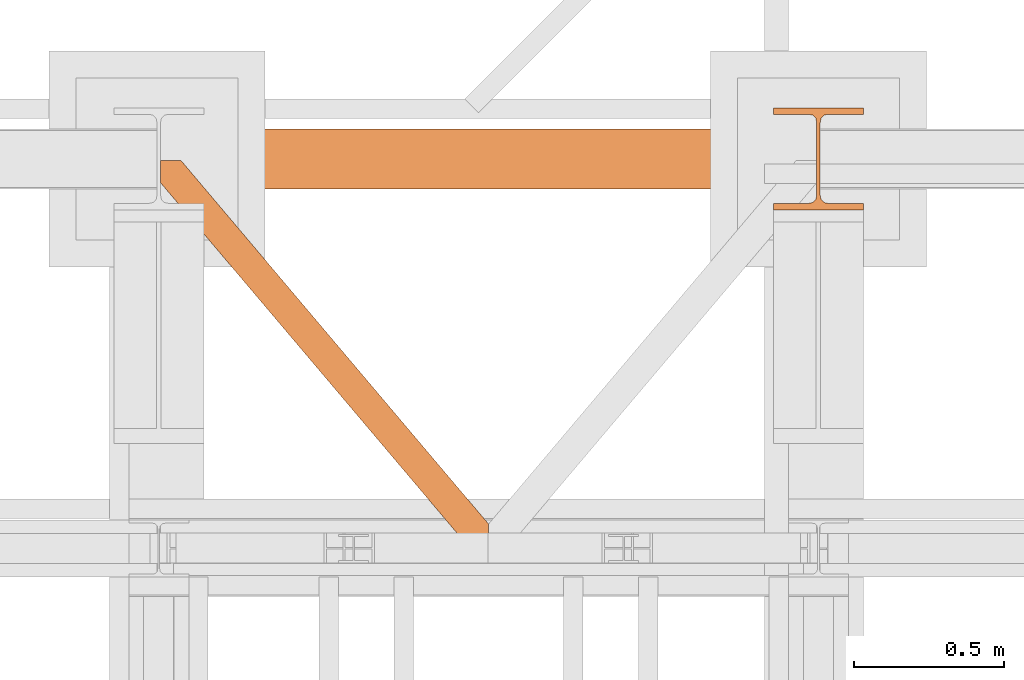
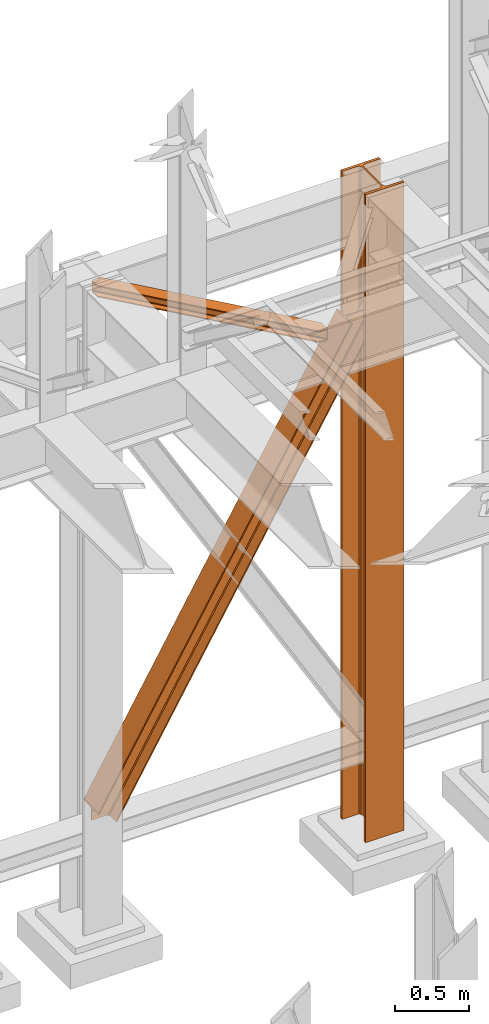
# One storey, part 192 of 208: 3 proxies.
"""IFC2X3 building model written with IfcOpenShell, lengths in millimetres."""

from ifc_helpers import new_model, entity, si_unit, converted_unit, frame, origin, origin_with_axes, place, context, subcontext, project, spatial, faceted_brep, material, element, save


model = new_model("IFC2X3")

# Units and contexts
model_context = context("Model", 3, precision=1e-05, world=origin())
plan_context = context("Plan", 3, precision=1e-05, world=origin())
body_context = subcontext(model_context, "Body", "Model", "MODEL_VIEW")
ifc_project = project(units=[si_unit("LENGTHUNIT", "METRE", prefix="MILLI"), converted_unit("PLANEANGLEUNIT", "DEGREE", entity("IfcPlaneAngleMeasure", 0.0174532925199433), si_unit("PLANEANGLEUNIT", "RADIAN"), dimensions=[0, 0, 0, 0, 0, 0, 0]), si_unit("AREAUNIT", "SQUARE_METRE"), si_unit("VOLUMEUNIT", "CUBIC_METRE")], contexts=[model_context, plan_context])

# Building, storey
building_placement = place(None, origin())
building = spatial("IfcBuilding", under=ifc_project, at=building_placement, CompositionType="COMPLEX")
storey_placement = place(building_placement, origin_with_axes())
storey = spatial("IfcBuildingStorey", under=building, at=storey_placement, Name="Geschoss", CompositionType="ELEMENT")

# Proxies
ifc_material = material(Name="35/80cm")
proxy_1_placement = place(storey_placement, frame((5343.254962568202, -12632.57439531566, -65.01000000000022), z_axis=(0.0, 0.0, 1.0), x_axis=(1.0, 0.0, 0.0)))
element("IfcBuildingElementProxy", 1, at=proxy_1_placement, inside=storey, material=ifc_material, context=body_context, shape_type="Brep", body=[
    faceted_brep([(300.0100119209292, 0.01000000000021828, 0.01000000000027512), (300.0100119209292, 21.51000631809256, 0.01000000000027512), (183.0100057816508, 21.51000631809256, 0.01000000000027512), (169.036290997863, 24.30682016372703, 0.01000000000027512), (158.8068282401564, 34.53628850936912, 0.01000000000027512), (156.0100060126188, 48.51000143051169, 0.01000000000027512), (156.0100060126188, 291.5099946951868, 0.01000000000027512), (158.8068282401564, 305.48371506691, 0.01000000000027512), (169.036290997863, 315.7131685113909, 0.01000000000027512), (183.0100057816508, 318.5099972581866, 0.01000000000027512), (300.0100119209292, 318.5099972581866, 0.01000000000027512), (300.0100119209292, 340.0100035762789, 0.01000000000027512), (0.01000000000021828, 340.0100035762789, 0.01000000000027512), (0.01000000000021828, 318.5099972581866, 0.01000000000027512), (117.0100061392786, 318.5099972581866, 0.01000000000027512), (130.9837209230664, 315.7131685113909, 0.01000000000027512), (141.213183680773, 305.48371506691, 0.01000000000027512), (144.0100059083106, 291.5099946951868, 0.01000000000027512), (144.0100059083106, 48.51000143051169, 0.01000000000027512), (141.213183680773, 34.53628850936912, 0.01000000000027512), (130.9837209230664, 24.30682016372703, 0.01000000000027512), (117.0100061392786, 21.51000631809256, 0.01000000000027512), (0.01000000000021828, 21.51000631809256, 0.01000000000027512), (0.01000000000021828, 0.01000000000021828, 0.01000000000027512), (300.0100119209292, 21.51000631809256, 5350.010005364416), (300.0100119209292, 0.01000000000021828, 5350.010005364416), (0.01000000000021828, 0.01000000000021828, 5350.010005364416), (0.01000000000021828, 21.51000631809256, 5350.010005364416), (117.0100061392786, 21.51000631809256, 5350.010005364416), (130.9837209230664, 24.30682016372703, 5350.010005364416), (141.213183680773, 34.53628850936912, 5350.010005364416), (144.0100059083106, 48.51000143051169, 5350.010005364416), (144.0100059083106, 291.5099946951868, 5350.010005364416), (141.213183680773, 305.48371506691, 5350.010005364416), (130.9837209230664, 315.7131685113909, 5350.010005364416), (117.0100061392786, 318.5099972581866, 5350.010005364416), (0.01000000000021828, 318.5099972581866, 5350.010005364416), (0.01000000000021828, 340.0100035762789, 5350.010005364416), (300.0100119209292, 340.0100035762789, 5350.010005364416), (300.0100119209292, 318.5099972581866, 5350.010005364416), (183.0100057816508, 318.5099972581866, 5350.010005364416), (169.036290997863, 315.7131685113909, 5350.010005364416), (158.8068282401564, 305.48371506691, 5350.010005364416), (156.0100060126188, 291.5099946951868, 5350.010005364416), (156.0100060126188, 48.51000143051169, 5350.010005364416), (158.8068282401564, 34.53628850936912, 5350.010005364416), (169.036290997863, 24.30682016372703, 5350.010005364416), (183.0100057816508, 21.51000631809256, 5350.010005364416), (300.0100119209292, 21.51000631809256, 0.01000000000027512), (300.0100119209292, 0.01000000000021828, 0.01000000000027512), (300.0100119209292, 0.01000000000021828, 5350.010005364416), (300.0100119209292, 21.51000631809256, 5350.010005364416), (183.0100057816508, 21.51000631809256, 0.01000000000027512), (300.0100119209292, 21.51000631809256, 0.01000000000027512), (300.0100119209292, 21.51000631809256, 5350.010005364416), (183.0100057816508, 21.51000631809256, 5350.010005364416), (169.036290997863, 24.30682016372703, 0.01000000000027512), (183.0100057816508, 21.51000631809256, 0.01000000000027512), (183.0100057816508, 21.51000631809256, 5350.010005364416), (169.036290997863, 24.30682016372703, 5350.010005364416), (158.8068282401564, 34.53628850936912, 0.01000000000027512), (169.036290997863, 24.30682016372703, 0.01000000000027512), (169.036290997863, 24.30682016372703, 5350.010005364416), (158.8068282401564, 34.53628850936912, 5350.010005364416), (156.0100060126188, 48.51000143051169, 0.01000000000027512), (158.8068282401564, 34.53628850936912, 0.01000000000027512), (158.8068282401564, 34.53628850936912, 5350.010005364416), (156.0100060126188, 48.51000143051169, 5350.010005364416), (156.0100060126188, 291.5099946951868, 0.01000000000027512), (156.0100060126188, 48.51000143051169, 0.01000000000027512), (156.0100060126188, 48.51000143051169, 5350.010005364416), (156.0100060126188, 291.5099946951868, 5350.010005364416), (158.8068282401564, 305.48371506691, 0.01000000000027512), (156.0100060126188, 291.5099946951868, 0.01000000000027512), (156.0100060126188, 291.5099946951868, 5350.010005364416), (158.8068282401564, 305.48371506691, 5350.010005364416), (169.036290997863, 315.7131685113909, 0.01000000000027512), (158.8068282401564, 305.48371506691, 0.01000000000027512), (158.8068282401564, 305.48371506691, 5350.010005364416), (169.036290997863, 315.7131685113909, 5350.010005364416), (183.0100057816508, 318.5099972581866, 0.01000000000027512), (169.036290997863, 315.7131685113909, 0.01000000000027512), (169.036290997863, 315.7131685113909, 5350.010005364416), (183.0100057816508, 318.5099972581866, 5350.010005364416), (300.0100119209292, 318.5099972581866, 0.01000000000027512), (183.0100057816508, 318.5099972581866, 0.01000000000027512), (183.0100057816508, 318.5099972581866, 5350.010005364416), (300.0100119209292, 318.5099972581866, 5350.010005364416), (300.0100119209292, 340.0100035762789, 0.01000000000027512), (300.0100119209292, 318.5099972581866, 0.01000000000027512), (300.0100119209292, 318.5099972581866, 5350.010005364416), (300.0100119209292, 340.0100035762789, 5350.010005364416), (0.01000000000021828, 340.0100035762789, 0.01000000000027512), (300.0100119209292, 340.0100035762789, 0.01000000000027512), (300.0100119209292, 340.0100035762789, 5350.010005364416), (0.01000000000021828, 340.0100035762789, 5350.010005364416), (0.01000000000021828, 318.5099972581866, 0.01000000000027512), (0.01000000000021828, 340.0100035762789, 0.01000000000027512), (0.01000000000021828, 340.0100035762789, 5350.010005364416), (0.01000000000021828, 318.5099972581866, 5350.010005364416), (117.0100061392786, 318.5099972581866, 0.01000000000027512), (0.01000000000021828, 318.5099972581866, 0.01000000000027512), (0.01000000000021828, 318.5099972581866, 5350.010005364416), (117.0100061392786, 318.5099972581866, 5350.010005364416), (130.9837209230664, 315.7131685113909, 0.01000000000027512), (117.0100061392786, 318.5099972581866, 0.01000000000027512), (117.0100061392786, 318.5099972581866, 5350.010005364416), (130.9837209230664, 315.7131685113909, 5350.010005364416), (141.213183680773, 305.48371506691, 0.01000000000027512), (130.9837209230664, 315.7131685113909, 0.01000000000027512), (130.9837209230664, 315.7131685113909, 5350.010005364416), (141.213183680773, 305.48371506691, 5350.010005364416), (144.0100059083106, 291.5099946951868, 0.01000000000027512), (141.213183680773, 305.48371506691, 0.01000000000027512), (141.213183680773, 305.48371506691, 5350.010005364416), (144.0100059083106, 291.5099946951868, 5350.010005364416), (144.0100059083106, 48.51000143051169, 0.01000000000027512), (144.0100059083106, 291.5099946951868, 0.01000000000027512), (144.0100059083106, 291.5099946951868, 5350.010005364416), (144.0100059083106, 48.51000143051169, 5350.010005364416), (141.213183680773, 34.53628850936912, 0.01000000000027512), (144.0100059083106, 48.51000143051169, 0.01000000000027512), (144.0100059083106, 48.51000143051169, 5350.010005364416), (141.213183680773, 34.53628850936912, 5350.010005364416), (130.9837209230664, 24.30682016372703, 0.01000000000027512), (141.213183680773, 34.53628850936912, 0.01000000000027512), (141.213183680773, 34.53628850936912, 5350.010005364416), (130.9837209230664, 24.30682016372703, 5350.010005364416), (117.0100061392786, 21.51000631809256, 0.01000000000027512), (130.9837209230664, 24.30682016372703, 0.01000000000027512), (130.9837209230664, 24.30682016372703, 5350.010005364416), (117.0100061392786, 21.51000631809256, 5350.010005364416), (0.01000000000021828, 21.51000631809256, 0.01000000000027512), (117.0100061392786, 21.51000631809256, 0.01000000000027512), (117.0100061392786, 21.51000631809256, 5350.010005364416), (0.01000000000021828, 21.51000631809256, 5350.010005364416), (0.01000000000021828, 0.01000000000021828, 0.01000000000027512), (0.01000000000021828, 21.51000631809256, 0.01000000000027512), (0.01000000000021828, 21.51000631809256, 5350.010005364416), (0.01000000000021828, 0.01000000000021828, 5350.010005364416), (300.0100119209292, 0.01000000000021828, 0.01000000000027512), (0.01000000000021828, 0.01000000000021828, 0.01000000000027512), (0.01000000000021828, 0.01000000000021828, 5350.010005364416), (300.0100119209292, 0.01000000000021828, 5350.010005364416)], [[[0, 1, 2, 3, 4, 5, 6, 7, 8, 9, 10, 11, 12, 13, 14, 15, 16, 17, 18, 19, 20, 21, 22, 23]], [[24, 25, 26, 27, 28, 29, 30, 31, 32, 33, 34, 35, 36, 37, 38, 39, 40, 41, 42, 43, 44, 45, 46, 47]], [[48, 49, 50, 51]], [[52, 53, 54, 55]], [[56, 57, 58, 59]], [[60, 61, 62, 63]], [[64, 65, 66, 67]], [[68, 69, 70, 71]], [[72, 73, 74, 75]], [[76, 77, 78, 79]], [[80, 81, 82, 83]], [[84, 85, 86, 87]], [[88, 89, 90, 91]], [[92, 93, 94, 95]], [[96, 97, 98, 99]], [[100, 101, 102, 103]], [[104, 105, 106, 107]], [[108, 109, 110, 111]], [[112, 113, 114, 115]], [[116, 117, 118, 119]], [[120, 121, 122, 123]], [[124, 125, 126, 127]], [[128, 129, 130, 131]], [[132, 133, 134, 135]], [[136, 137, 138, 139]], [[140, 141, 142, 143]]], orient=[[False], [False], [False], [False], [False], [False], [False], [False], [False], [False], [False], [False], [False], [False], [False], [False], [False], [False], [False], [False], [False], [False], [False], [False], [False], [False]]),
])
proxy_2_placement = place(storey_placement, frame((3299.25488355921, -12562.57439501764, 734.9900149335328), z_axis=(0.0, 0.0, 1.0), x_axis=(1.0, 0.0, 0.0)))
element("IfcBuildingElementProxy", 2, at=proxy_2_placement, inside=storey, context=body_context, shape_type="Brep", body=[
    faceted_brep([(0.01008502161312208, 0.01000000000021828, 120.8497915510924), (0.01008502161312208, 200.0100029802325, 120.8497915510924), (1970.595410063093, 200.0100029802325, 3468.009977913908), (1970.595410063093, 0.01000000000021828, 3468.009977913908), (0.01008502161312208, 200.0100029802325, 120.8497915510924), (0.01008502161266733, 200.0100029802325, 101.4682129393398), (1982.007890767009, 200.0100029802325, 3468.009977913908), (1970.595410063093, 200.0100029802325, 3468.009977913908), (0.01008502161266733, 200.0100029802325, 101.4682129393398), (0.01008502127388056, 121.2600035762789, 101.4681984983711), (1982.007899269971, 121.2600035762789, 3468.009977913908), (1982.007890767009, 200.0100029802325, 3468.009977913908), (0.01008502127388056, 121.2600035762789, 101.4681984983711), (0.009999999999308784, 111.9441915473344, 97.85427409430258), (1984.135808151258, 111.9441915473344, 3468.009977913909), (1982.007899269971, 121.2600035762789, 3468.009977913908), (0.009999999999308784, 111.9441915473344, 97.85427409430258), (0.01008502161312208, 105.1245498640838, 84.63689245399041), (1991.918714280975, 105.1245498640838, 3468.009977913908), (1984.135808151258, 111.9441915473344, 3468.009977913909), (0.01008502161312208, 105.1245498640838, 84.63689245399041), (0.01008502161312208, 103.2600015571716, 66.58142866151923), (2002.550367938204, 103.2600015571716, 3468.009977913908), (1991.918714280975, 105.1245498640838, 3468.009977913908), (0.01008502161312208, 103.2600015571716, 0.009999999999990905), (113.7187158034394, 103.2600015571716, 0.01000000000021828), (2155.477653586077, 103.2600015571716, 3468.009977913908), (2002.550367938204, 103.2600015571716, 3468.009977913908), (0.01008502161312208, 103.2600015571716, 66.58142866151923), (113.7187158034394, 103.2600015571716, 0.01000000000021828), (124.3486060538462, 105.1245498640838, 0.01000000000010459), (2166.109307243306, 105.1245498640838, 3468.009977913908), (2155.477653586077, 103.2600015571716, 3468.009977913908), (124.3486060538462, 105.1245498640838, 0.01000000000010459), (132.1302232850376, 111.9441915473344, 0.009999999999763531), (2173.892213373022, 111.9441915473344, 3468.009977913908), (2166.109307243306, 105.1245498640838, 3468.009977913908), (132.1302232850376, 111.9441915473344, 0.009999999999763531), (134.2577800655363, 121.2600035762789, 0.009999999999763531), (2176.020122254309, 121.2600035762789, 3468.009977913907), (2173.892213373022, 111.9441915473344, 3468.009977913908), (134.2577800655363, 121.2600035762789, 0.009999999999763531), (134.2577800655363, 200.0100029802325, 0.009999999999763531), (2176.020122254308, 200.0100029802325, 3468.009977913907), (2176.020122254309, 121.2600035762789, 3468.009977913907), (134.2577800655363, 200.0100029802325, 0.009999999999763531), (145.668374522566, 200.0100029802325, 0.009999999999990905), (2187.432602958224, 200.0100029802325, 3468.009977913908), (2176.020122254308, 200.0100029802325, 3468.009977913907), (145.668374522566, 200.0100029802325, 0.009999999999990905), (145.668374522566, 0.01000000000021828, 0.009999999999990905), (2187.432602958224, 0.01000000000021828, 3468.009977913908), (2187.432602958224, 200.0100029802325, 3468.009977913908), (145.668374522566, 0.01000000000021828, 0.009999999999990905), (134.2577800655363, 0.01000000000021828, 0.009999999999877218), (2176.020122254308, 0.01000000000021828, 3468.009977913908), (2187.432602958224, 0.01000000000021828, 3468.009977913908), (134.2577800655363, 0.01000000000021828, 0.009999999999877218), (134.2577800655363, 78.75999940395377, 0.009999999999763531), (2176.020122254308, 78.75999940395377, 3468.009977913907), (2176.020122254308, 0.01000000000021828, 3468.009977913908), (134.2577800655363, 78.75999940395377, 0.009999999999763531), (132.1302232850376, 88.07581143289826, 0.009999999999763531), (2173.892213373022, 88.07581143290008, 3468.009977913908), (2176.020122254308, 78.75999940395377, 3468.009977913907), (132.1302232850376, 88.07581143289826, 0.009999999999763531), (124.3486060538457, 94.89545311614893, 0.009999999999763531), (2166.109307243306, 94.89545311614893, 3468.009977913908), (2173.892213373022, 88.07581143290008, 3468.009977913908), (124.3486060538457, 94.89545311614893, 0.009999999999763531), (113.7187158034394, 96.76000142306111, 0.01000000000021828), (2155.477653586077, 96.76000142306111, 3468.009977913908), (2166.109307243306, 94.89545311614893, 3468.009977913908), (113.7187158034394, 96.76000142306111, 0.01000000000021828), (0.01008502161266733, 96.76000142306111, 0.009999999999990905), (0.01008502161312208, 96.76000142306111, 66.58142866151888), (2002.550367938204, 96.76000142306111, 3468.009977913908), (2155.477653586077, 96.76000142306111, 3468.009977913908), (0.01008502161312208, 96.76000142306111, 66.58142866151888), (0.01008502161312208, 94.89545311615075, 84.63689245399041), (1991.918714280975, 94.89545311614893, 3468.009977913908), (2002.550367938204, 96.76000142306111, 3468.009977913908), (0.01008502161312208, 94.89545311615075, 84.63689245399041), (0.01008502161312208, 88.07581143289826, 97.85441850857092), (1984.135808151258, 88.07581143289826, 3468.009977913909), (1991.918714280975, 94.89545311614893, 3468.009977913908), (0.01008502161312208, 88.07581143289826, 97.85441850857092), (0.01016988588980894, 78.75999940395377, 101.4683426459951), (1982.007899269971, 78.75999940395377, 3468.009977913908), (1984.135808151258, 88.07581143289826, 3468.009977913909), (0.01016988588980894, 78.75999940395377, 101.4683426459951), (0.0100850219523636, 0.01000000000021828, 101.4682129399164), (1982.007890767009, 0.01000000000021828, 3468.009977913908), (1982.007899269971, 78.75999940395377, 3468.009977913908), (0.0100850219523636, 0.01000000000021828, 101.4682129399164), (0.01008502161312208, 0.01000000000021828, 120.8497915510924), (1970.595410063093, 0.01000000000021828, 3468.009977913908), (1982.007890767009, 0.01000000000021828, 3468.009977913908), (1970.595410063093, 0.01000000000021828, 3468.009977913908), (1970.595410063093, 200.0100029802325, 3468.009977913908), (1982.007890767009, 200.0100029802325, 3468.009977913908), (1982.007899269971, 121.2600035762789, 3468.009977913908), (1984.135808151258, 111.9441915473344, 3468.009977913909), (1991.918714280975, 105.1245498640838, 3468.009977913908), (2002.550367938204, 103.2600015571716, 3468.009977913908), (2155.477653586077, 103.2600015571716, 3468.009977913908), (2166.109307243306, 105.1245498640838, 3468.009977913908), (2173.892213373022, 111.9441915473344, 3468.009977913908), (2176.020122254309, 121.2600035762789, 3468.009977913907), (2176.020122254308, 200.0100029802325, 3468.009977913907), (2187.432602958224, 200.0100029802325, 3468.009977913908), (2187.432602958224, 0.01000000000021828, 3468.009977913908), (2176.020122254308, 0.01000000000021828, 3468.009977913908), (2176.020122254308, 78.75999940395377, 3468.009977913907), (2173.892213373022, 88.07581143290008, 3468.009977913908), (2166.109307243306, 94.89545311614893, 3468.009977913908), (2155.477653586077, 96.76000142306111, 3468.009977913908), (2002.550367938204, 96.76000142306111, 3468.009977913908), (1991.918714280975, 94.89545311614893, 3468.009977913908), (1984.135808151258, 88.07581143289826, 3468.009977913909), (1982.007899269971, 78.75999940395377, 3468.009977913908), (1982.007890767009, 0.01000000000021828, 3468.009977913908), (0.01008502161266733, 96.76000142306111, 0.009999999999990905), (0.01008502161312208, 103.2600015571716, 0.009999999999990905), (0.01008502161312208, 103.2600015571716, 66.58142866151923), (0.01008502161312208, 105.1245498640838, 84.63689245399041), (0.009999999999308784, 111.9441915473344, 97.85427409430258), (0.01008502127388056, 121.2600035762789, 101.4681984983711), (0.01008502161266733, 200.0100029802325, 101.4682129393398), (0.01008502161312208, 200.0100029802325, 120.8497915510924), (0.01008502161312208, 0.01000000000021828, 120.8497915510924), (0.0100850219523636, 0.01000000000021828, 101.4682129399164), (0.01016988588980894, 78.75999940395377, 101.4683426459951), (0.01008502161312208, 88.07581143289826, 97.85441850857092), (0.01008502161312208, 94.89545311615075, 84.63689245399041), (0.01008502161312208, 96.76000142306111, 66.58142866151888), (113.7187158034394, 103.2600015571716, 0.01000000000021828), (0.01008502161312208, 103.2600015571716, 0.009999999999990905), (0.01008502161266733, 96.76000142306111, 0.009999999999990905), (113.7187158034394, 96.76000142306111, 0.01000000000021828), (124.3486060538457, 94.89545311614893, 0.009999999999763531), (132.1302232850376, 88.07581143289826, 0.009999999999763531), (134.2577800655363, 78.75999940395377, 0.009999999999763531), (134.2577800655363, 0.01000000000021828, 0.009999999999877218), (145.668374522566, 0.01000000000021828, 0.009999999999990905), (145.668374522566, 200.0100029802325, 0.009999999999990905), (134.2577800655363, 200.0100029802325, 0.009999999999763531), (134.2577800655363, 121.2600035762789, 0.009999999999763531), (132.1302232850376, 111.9441915473344, 0.009999999999763531), (124.3486060538462, 105.1245498640838, 0.01000000000010459)], [[[0, 1, 2, 3]], [[4, 5, 6, 7]], [[8, 9, 10, 11]], [[12, 13, 14, 15]], [[16, 17, 18, 19]], [[20, 21, 22, 23]], [[24, 25, 26, 27, 28]], [[29, 30, 31, 32]], [[33, 34, 35, 36]], [[37, 38, 39, 40]], [[41, 42, 43, 44]], [[45, 46, 47, 48]], [[49, 50, 51, 52]], [[53, 54, 55, 56]], [[57, 58, 59, 60]], [[61, 62, 63, 64]], [[65, 66, 67, 68]], [[69, 70, 71, 72]], [[73, 74, 75, 76, 77]], [[78, 79, 80, 81]], [[82, 83, 84, 85]], [[86, 87, 88, 89]], [[90, 91, 92, 93]], [[94, 95, 96, 97]], [[98, 99, 100, 101, 102, 103, 104, 105, 106, 107, 108, 109, 110, 111, 112, 113, 114, 115, 116, 117, 118, 119, 120, 121]], [[122, 123, 124, 125, 126, 127, 128, 129, 130, 131, 132, 133, 134, 135]], [[136, 137, 138, 139, 140, 141, 142, 143, 144, 145, 146, 147, 148, 149]]], orient=[[False], [False], [False], [False], [False], [False], [False], [False], [False], [False], [False], [False], [False], [False], [False], [False], [False], [False], [False], [False], [False], [False], [False], [False], [False], [False], [False]]),
])
proxy_3_placement = place(storey_placement, frame((3299.254968580829, -13757.87439038569, 5101.990016164881), z_axis=(0.0, 0.0, 1.0), x_axis=(1.0, 0.0, 0.0)))
element("IfcBuildingElementProxy", 3, at=proxy_3_placement, inside=storey, context=body_context, shape_type="Brep", body=[
    faceted_brep([(1028.512359102907, 0.00999999999839929, 8.010001311302403), (1028.512359102907, 0.00999999999839929, 0.01000000000021828), (0.01000000000021828, 1215.51278803071, 0.01000000000021828), (0.01000000000021828, 1215.51278803071, 8.010001311303313), (1028.512359102907, 0.00999999999839929, 0.01000000000021828), (1094.009999947843, 0.00999999999839929, 0.01000000000021828), (1094.009999947843, 77.41630281674588, 0.01000000000021828), (67.46148411605282, 1290.610003345229, 0.01000000000021828), (0.01000000000021828, 1290.610003345229, 0.01000000000021828), (0.01000000000021828, 1215.51278803071, 0.01000000000021828), (1094.009999947843, 77.41630281674588, 0.01000000000021828), (1094.009999947845, 77.41630281674406, 8.010001311302403), (67.46148411605282, 1290.610003345229, 8.010001311302403), (67.46148411605282, 1290.610003345229, 0.01000000000021828), (1094.009999947845, 77.41630281674406, 8.010001311302403), (1094.009999947843, 22.45782827823314, 8.010001311302403), (20.95815950654287, 1290.610003345229, 8.010001311302403), (67.46148411605282, 1290.610003345229, 8.010001311302403), (1094.009999947843, 22.45782827823314, 8.010001311302403), (1094.009999947844, 12.84312897135715, 9.253033826351384), (12.82264470841801, 1290.610003345229, 9.253033826351384), (20.95815950654287, 1290.610003345229, 8.010001311302403), (1094.009999947844, 12.84312897135715, 9.253033826351384), (1094.009999947844, 5.804685632949258, 13.79946006298087), (6.86703880668756, 1290.610003345229, 13.79946006298087), (12.82264470841801, 1290.610003345229, 9.253033826351384), (1094.009999947844, 5.804685632949258, 13.79946006298087), (1094.009999947843, 3.880315357107975, 20.01000141561053), (5.23872549636144, 1290.610003345229, 20.01000141560962), (6.86703880668756, 1290.610003345229, 13.79946006298087), (1094.009999947843, 3.880315357107975, 20.01000141561053), (1094.009999947843, 3.880315357109794, 76.01000128150008), (5.23872549636144, 1290.610003345229, 76.01000128150008), (5.23872549636144, 1290.610003345229, 20.01000141560962), (1094.009999947843, 3.880315357109794, 76.01000128150008), (1094.009999947844, 5.804685632949258, 82.2205407714846), (6.86703880668847, 1290.610003345229, 82.2205407714846), (5.23872549636144, 1290.610003345229, 76.01000128150008), (1094.009999947844, 5.804685632949258, 82.2205407714846), (1094.009999947844, 12.84312897135715, 86.76696700811408), (12.82264470841892, 1290.610003345229, 86.76696700811317), (6.86703880668847, 1290.610003345229, 82.2205407714846), (1094.009999947844, 12.84312897135715, 86.76696700811408), (1094.009999947844, 22.45782827823314, 88.00999952316306), (20.95815950654469, 1290.610003345229, 88.00999952316306), (12.82264470841892, 1290.610003345229, 86.76696700811317), (1094.009999947844, 22.45782827823314, 88.00999952316306), (1094.009999947844, 77.41630281674588, 88.00999952316306), (67.46148411605373, 1290.610003345229, 88.00999952316397), (20.95815950654469, 1290.610003345229, 88.00999952316306), (1094.009999947844, 77.41630281674588, 88.00999952316306), (1094.009999947846, 77.41630281674225, 96.01000083446525), (67.46148411605373, 1290.610003345229, 96.01000083446525), (67.46148411605373, 1290.610003345229, 88.00999952316397), (1094.009999947846, 77.41630281674225, 96.01000083446525), (1094.009999947845, 0.00999999999839929, 96.01000083446525), (1028.512359102908, 0.00999999999839929, 96.01000083446525), (0.01000000000021828, 1215.51278803071, 96.01000083446525), (0.01000000000021828, 1290.610003345229, 96.01000083446525), (67.46148411605373, 1290.610003345229, 96.01000083446525), (1028.512359102908, 0.00999999999839929, 96.01000083446525), (1028.512359102908, 0.00999999999839929, 88.00999952316306), (0.01000000000021828, 1215.51278803071, 88.00999952316306), (0.01000000000021828, 1215.51278803071, 96.01000083446525), (1028.512359102908, 0.00999999999839929, 88.00999952316306), (1075.015683712419, 0.00999999999839929, 88.00999952316306), (0.01000000000021828, 1270.471262569223, 88.00999952316215), (0.01000000000021828, 1215.51278803071, 88.00999952316306), (1075.015683712419, 0.00999999999839929, 88.00999952316306), (1083.151198510544, 0.00999999999839929, 86.76696700811408), (0.01000000000021828, 1280.085961876101, 86.76696700811499), (0.01000000000021828, 1270.471262569223, 88.00999952316215), (1083.151198510544, 0.00999999999839929, 86.76696700811408), (1089.106804412273, 0.00999999999839929, 82.2205407714846), (0.01000000000021828, 1287.124405214507, 82.2205407714855), (0.01000000000021828, 1280.085961876101, 86.76696700811499), (1089.106804412273, 0.00999999999839929, 82.2205407714846), (1090.735117722601, 0.00999999999839929, 76.01000128150008), (0.01000000000021828, 1289.04877549035, 76.01000128150008), (0.01000000000021828, 1287.124405214507, 82.2205407714855), (1090.735117722601, 0.00999999999839929, 76.01000128150008), (1090.7351177226, 0.00999999999839929, 20.01000141561053), (0.01000000000021828, 1289.048775490348, 20.01000141561053), (0.01000000000021828, 1289.04877549035, 76.01000128150008), (1090.7351177226, 0.00999999999839929, 20.01000141561053), (1089.106804412274, 0.00999999999839929, 13.79946006298087), (0.01000000000021828, 1287.124405214507, 13.79946006298087), (0.01000000000021828, 1289.048775490348, 20.01000141561053), (1089.106804412274, 0.00999999999839929, 13.79946006298087), (1083.151198510544, 0.00999999999839929, 9.253033826351384), (0.01000000000021828, 1280.085961876099, 9.253033826351384), (0.01000000000021828, 1287.124405214507, 13.79946006298087), (1083.151198510544, 0.00999999999839929, 9.253033826351384), (1075.015683712417, 0.00999999999839929, 8.010001311302403), (0.01000000000021828, 1270.471262569225, 8.010001311302403), (0.01000000000021828, 1280.085961876099, 9.253033826351384), (1075.015683712417, 0.00999999999839929, 8.010001311302403), (1028.512359102907, 0.00999999999839929, 8.010001311302403), (0.01000000000021828, 1215.51278803071, 8.010001311303313), (0.01000000000021828, 1270.471262569225, 8.010001311302403), (1094.009999947843, 77.41630281674588, 0.01000000000021828), (1094.009999947843, 0.00999999999839929, 0.01000000000021828), (1094.009999947845, 0.00999999999839929, 96.01000083446525), (1094.009999947846, 77.41630281674225, 96.01000083446525), (1094.009999947844, 77.41630281674588, 88.00999952316306), (1094.009999947844, 22.45782827823314, 88.00999952316306), (1094.009999947844, 12.84312897135715, 86.76696700811408), (1094.009999947844, 5.804685632949258, 82.2205407714846), (1094.009999947843, 3.880315357109794, 76.01000128150008), (1094.009999947843, 3.880315357107975, 20.01000141561053), (1094.009999947844, 5.804685632949258, 13.79946006298087), (1094.009999947844, 12.84312897135715, 9.253033826351384), (1094.009999947843, 22.45782827823314, 8.010001311302403), (1094.009999947845, 77.41630281674406, 8.010001311302403), (1094.009999947845, 0.00999999999839929, 96.01000083446525), (1094.009999947843, 0.00999999999839929, 0.01000000000021828), (1028.512359102907, 0.00999999999839929, 0.01000000000021828), (1028.512359102907, 0.00999999999839929, 8.010001311302403), (1075.015683712417, 0.00999999999839929, 8.010001311302403), (1083.151198510544, 0.00999999999839929, 9.253033826351384), (1089.106804412274, 0.00999999999839929, 13.79946006298087), (1090.7351177226, 0.00999999999839929, 20.01000141561053), (1090.735117722601, 0.00999999999839929, 76.01000128150008), (1089.106804412273, 0.00999999999839929, 82.2205407714846), (1083.151198510544, 0.00999999999839929, 86.76696700811408), (1075.015683712419, 0.00999999999839929, 88.00999952316306), (1028.512359102908, 0.00999999999839929, 88.00999952316306), (1028.512359102908, 0.00999999999839929, 96.01000083446525), (0.01000000000021828, 1215.51278803071, 0.01000000000021828), (0.01000000000021828, 1290.610003345229, 0.01000000000021828), (0.01000000000021828, 1290.610003345229, 96.01000083446525), (0.01000000000021828, 1215.51278803071, 96.01000083446525), (0.01000000000021828, 1215.51278803071, 88.00999952316306), (0.01000000000021828, 1270.471262569223, 88.00999952316215), (0.01000000000021828, 1280.085961876101, 86.76696700811499), (0.01000000000021828, 1287.124405214507, 82.2205407714855), (0.01000000000021828, 1289.04877549035, 76.01000128150008), (0.01000000000021828, 1289.048775490348, 20.01000141561053), (0.01000000000021828, 1287.124405214507, 13.79946006298087), (0.01000000000021828, 1280.085961876099, 9.253033826351384), (0.01000000000021828, 1270.471262569225, 8.010001311302403), (0.01000000000021828, 1215.51278803071, 8.010001311303313), (67.46148411605282, 1290.610003345229, 0.01000000000021828), (67.46148411605282, 1290.610003345229, 8.010001311302403), (20.95815950654287, 1290.610003345229, 8.010001311302403), (12.82264470841801, 1290.610003345229, 9.253033826351384), (6.86703880668756, 1290.610003345229, 13.79946006298087), (5.23872549636144, 1290.610003345229, 20.01000141560962), (5.23872549636144, 1290.610003345229, 76.01000128150008), (6.86703880668847, 1290.610003345229, 82.2205407714846), (12.82264470841892, 1290.610003345229, 86.76696700811317), (20.95815950654469, 1290.610003345229, 88.00999952316306), (67.46148411605373, 1290.610003345229, 88.00999952316397), (67.46148411605373, 1290.610003345229, 96.01000083446525), (0.01000000000021828, 1290.610003345229, 96.01000083446525), (0.01000000000021828, 1290.610003345229, 0.01000000000021828)], [[[0, 1, 2, 3]], [[4, 5, 6, 7, 8, 9]], [[10, 11, 12, 13]], [[14, 15, 16, 17]], [[18, 19, 20, 21]], [[22, 23, 24, 25]], [[26, 27, 28, 29]], [[30, 31, 32, 33]], [[34, 35, 36, 37]], [[38, 39, 40, 41]], [[42, 43, 44, 45]], [[46, 47, 48, 49]], [[50, 51, 52, 53]], [[54, 55, 56, 57, 58, 59]], [[60, 61, 62, 63]], [[64, 65, 66, 67]], [[68, 69, 70, 71]], [[72, 73, 74, 75]], [[76, 77, 78, 79]], [[80, 81, 82, 83]], [[84, 85, 86, 87]], [[88, 89, 90, 91]], [[92, 93, 94, 95]], [[96, 97, 98, 99]], [[100, 101, 102, 103, 104, 105, 106, 107, 108, 109, 110, 111, 112, 113]], [[114, 115, 116, 117, 118, 119, 120, 121, 122, 123, 124, 125, 126, 127]], [[128, 129, 130, 131, 132, 133, 134, 135, 136, 137, 138, 139, 140, 141]], [[142, 143, 144, 145, 146, 147, 148, 149, 150, 151, 152, 153, 154, 155]]], orient=[[False], [False], [False], [False], [False], [False], [False], [False], [False], [False], [False], [False], [False], [False], [False], [False], [False], [False], [False], [False], [False], [False], [False], [False], [False], [False], [False], [False]]),
])

save(model, "model.ifc")
